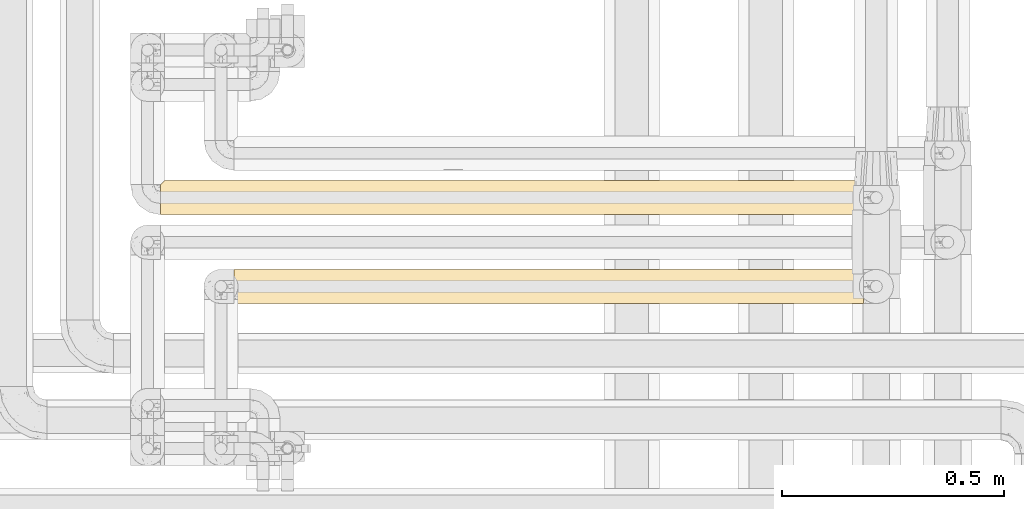
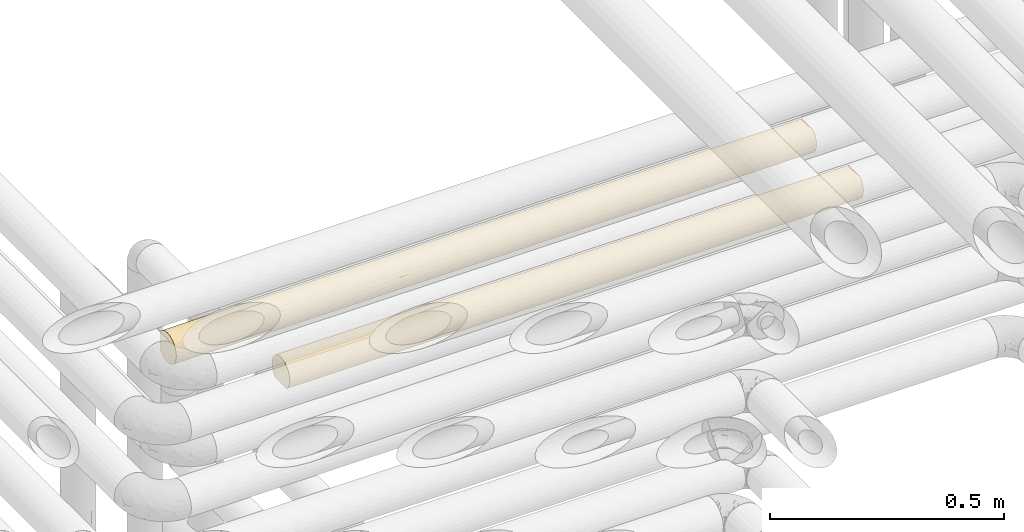
# One storey, part 39 of 827: 2 coverings.
"""IFC2X3 building model written with IfcOpenShell, lengths in millimetres."""

from ifc_helpers import new_model, entity, si_unit, converted_unit, derived_unit, direction, frame, origin, place, context, subcontext, project, spatial, faceted_brep, element, save


model = new_model("IFC2X3")

# Units and contexts
model_context = context("Model", 3, precision=0.01, world=origin(), true_north=direction((6.12303176911189e-17, 1.0)))
body_context = subcontext(model_context, "Body", "Model", "MODEL_VIEW")
ifc_project = project(units=[si_unit("LENGTHUNIT", "METRE", prefix="MILLI"), si_unit("AREAUNIT", "SQUARE_METRE"), si_unit("VOLUMEUNIT", "CUBIC_METRE"), converted_unit("PLANEANGLEUNIT", "DEGREE", entity("IfcRatioMeasure", 0.0174532925199433), si_unit("PLANEANGLEUNIT", "RADIAN"), dimensions=[0, 0, 0, 0, 0, 0, 0]), si_unit("MASSUNIT", "GRAM", prefix="KILO"), derived_unit("MASSDENSITYUNIT", [(si_unit("MASSUNIT", "GRAM", prefix="KILO"), 1), (si_unit("LENGTHUNIT", "METRE"), -3)]), derived_unit("MOMENTOFINERTIAUNIT", [(si_unit("LENGTHUNIT", "METRE"), 4)]), si_unit("TIMEUNIT", "SECOND"), si_unit("FREQUENCYUNIT", "HERTZ"), si_unit("THERMODYNAMICTEMPERATUREUNIT", "DEGREE_CELSIUS"), derived_unit("THERMALTRANSMITTANCEUNIT", [(si_unit("MASSUNIT", "GRAM", prefix="KILO"), 1), (si_unit("THERMODYNAMICTEMPERATUREUNIT", "KELVIN"), -1), (si_unit("TIMEUNIT", "SECOND"), -3)]), derived_unit("VOLUMETRICFLOWRATEUNIT", [(si_unit("LENGTHUNIT", "METRE"), 3), (si_unit("TIMEUNIT", "SECOND"), -1)]), derived_unit("MASSFLOWRATEUNIT", [(si_unit("MASSUNIT", "GRAM", prefix="KILO"), 1), (si_unit("TIMEUNIT", "SECOND"), -1)]), derived_unit("ROTATIONALFREQUENCYUNIT", [(si_unit("TIMEUNIT", "SECOND"), -1)]), si_unit("ELECTRICCURRENTUNIT", "AMPERE"), si_unit("ELECTRICVOLTAGEUNIT", "VOLT"), si_unit("POWERUNIT", "WATT"), si_unit("FORCEUNIT", "NEWTON", prefix="KILO"), si_unit("ILLUMINANCEUNIT", "LUX"), si_unit("LUMINOUSFLUXUNIT", "LUMEN"), si_unit("LUMINOUSINTENSITYUNIT", "CANDELA"), derived_unit("USERDEFINED", [(si_unit("MASSUNIT", "GRAM", prefix="KILO"), -1), (si_unit("LENGTHUNIT", "METRE"), -2), (si_unit("TIMEUNIT", "SECOND"), 3), (si_unit("LUMINOUSFLUXUNIT", "LUMEN"), 1)]), derived_unit("LINEARVELOCITYUNIT", [(si_unit("LENGTHUNIT", "METRE"), 1), (si_unit("TIMEUNIT", "SECOND"), -1)]), si_unit("PRESSUREUNIT", "PASCAL"), derived_unit("USERDEFINED", [(si_unit("LENGTHUNIT", "METRE"), -2), (si_unit("MASSUNIT", "GRAM", prefix="KILO"), 1), (si_unit("TIMEUNIT", "SECOND"), -2)]), derived_unit("LINEARFORCEUNIT", [(si_unit("MASSUNIT", "GRAM", prefix="KILO"), 1), (si_unit("LENGTHUNIT", "METRE"), 1), (si_unit("TIMEUNIT", "SECOND"), -2), (si_unit("LENGTHUNIT", "METRE"), -1)]), derived_unit("PLANARFORCEUNIT", [(si_unit("MASSUNIT", "GRAM", prefix="KILO"), 1), (si_unit("LENGTHUNIT", "METRE"), 1), (si_unit("TIMEUNIT", "SECOND"), -2), (si_unit("LENGTHUNIT", "METRE"), -2)])], contexts=[model_context])

# Site, building, storey
site_placement = place(None, origin())
site = spatial("IfcSite", under=ifc_project, at=site_placement, CompositionType="ELEMENT")
building_placement = place(site_placement, origin())
building = spatial("IfcBuilding", under=site, at=building_placement, CompositionType="ELEMENT")
storey_placement = place(building_placement, frame((0.0, 0.0, 28200.0)))
storey = spatial("IfcBuildingStorey", under=building, at=storey_placement, Name="08", CompositionType="ELEMENT", Elevation=28200.0)

# Coverings
covering_1_placement = place(storey_placement, frame((34855.35, 15450.0, 2960.0)))
element("IfcCovering", 1, at=covering_1_placement, inside=storey, Name=":ADSK_", ObjectType=":ADSK_", PredefinedType="INSULATION", context=body_context, shape_type="Brep", body=[
    faceted_brep([(1584.27, 59.2, 6.74), (1584.27, 67.15, 12.84), (1584.27, 73.25, 20.8), (1584.27, 77.09, 30.06), (1584.27, 78.4, 40.0), (1584.27, 77.51, 48.2), (1584.27, 74.9, 56.01), (1584.27, 70.68, 63.08), (1584.27, 65.05, 69.1), (1584.27, 14.94, 69.1), (1584.27, 9.31, 63.08), (1584.27, 5.09, 56.01), (1584.27, 2.48, 48.2), (1584.27, 1.6, 40.0), (1584.27, 2.9, 30.06), (1584.27, 6.74, 20.8), (1584.27, 12.84, 12.84), (1584.27, 20.8, 6.74), (1584.27, 30.06, 2.9), (1584.27, 40.0, 1.6), (1584.27, 49.93, 2.9), (1.6, 69.1, 14.94), (1.6, 63.08, 9.31), (1.6, 56.01, 5.09), (1.6, 48.2, 2.48), (1.6, 40.0, 1.6), (1.6, 30.06, 2.9), (1.6, 20.8, 6.74), (1.6, 12.84, 12.84), (1.6, 6.74, 20.8), (1.6, 2.9, 30.06), (1.6, 1.6, 40.0), (1.6, 2.9, 49.93), (1.6, 6.74, 59.2), (1.6, 12.84, 67.15), (1.6, 20.8, 73.25), (1.6, 30.06, 77.09), (1.6, 40.0, 78.4), (1.6, 48.2, 77.51), (1.6, 56.01, 74.9), (1.6, 63.08, 70.68), (1.6, 69.1, 65.05), (325.87, 16.62, 9.53), (1101.67, 12.02, 13.69), (1280.29, 16.62, 9.53), (1328.74, 9.53, 16.62), (260.79, 9.53, 16.62), (326.15, 2.41, 32.1), (223.22, 4.85, 24.51), (474.15, 4.52, 25.3), (1364.31, 33.26, 2.19), (1368.52, 25.3, 4.52), (574.48, 2.26, 32.88), (434.34, 1.6, 40.0), (780.34, 4.5, 25.35), (1274.34, 2.38, 32.28), (1367.89, 1.6, 40.0), (1225.68, 1.6, 40.0), (1137.67, 32.77, 2.28), (1225.68, 40.0, 1.6), (563.24, 33.12, 2.22), (819.98, 27.92, 3.54), (531.31, 25.3, 4.52), (246.65, 25.3, 4.52), (326.15, 32.71, 2.29), (567.7, 11.37, 14.4), (1398.66, 4.08, 26.39), (826.08, 2.33, 32.52), (804.78, 18.31, 8.3), (874.6, 9.53, 16.62), (1108.65, 25.3, 4.52), (1046.38, 2.24, 33.01), (564.73, 17.59, 8.81), (217.97, 40.0, 1.6), (217.97, 1.6, 40.0), (1045.77, 18.18, 8.39), (1151.52, 1.6, 40.0), (935.15, 1.6, 40.0), (867.09, 1.6, 40.0), (1066.7, 7.45, 19.62), (434.34, 40.0, 1.6), (650.71, 40.0, 1.6), (867.09, 40.0, 1.6), (1367.89, 40.0, 1.6), (1151.52, 40.0, 1.6), (650.71, 1.6, 40.0), (982.71, 4.52, 25.29), (1185.09, 4.52, 25.3), (718.77, 1.6, 40.0), (616.82, 49.74, 2.85), (287.23, 52.17, 3.58), (1009.3, 52.1, 3.55), (1259.71, 47.13, 2.26), (218.66, 59.66, 7.01), (712.29, 74.49, 23.13), (923.73, 76.93, 29.51), (906.39, 73.76, 21.71), (1375.48, 75.47, 25.3), (1364.99, 77.79, 33.21), (287.24, 66.24, 11.96), (544.14, 66.56, 12.26), (485.18, 59.66, 7.01), (830.9, 47.59, 2.35), (778.98, 54.79, 4.56), (227.27, 78.4, 40.0), (335.45, 77.5, 31.75), (10.29, 77.79, 33.21), (688.07, 76.94, 29.53), (384.99, 74.58, 23.31), (1137.87, 77.72, 32.83), (1230.33, 78.4, 40.0), (1367.59, 63.37, 9.53), (194.06, 71.13, 17.51), (8.5, 76.0, 26.63), (406.86, 70.58, 16.78), (1284.83, 70.46, 16.62), (1121.37, 75.47, 25.3), (1309.49, 54.69, 4.52), (443.64, 78.4, 40.0), (955.85, 68.71, 14.5), (795.9, 61.58, 8.23), (717.19, 70.91, 17.22), (1106.96, 63.37, 9.53), (5.57, 73.07, 20.48), (10.9, 78.4, 40.0), (876.39, 78.4, 40.0), (660.01, 78.4, 40.0), (335.45, 77.5, 48.24), (688.07, 76.94, 50.46), (1324.14, 72.98, 59.66), (1165.25, 68.03, 66.24), (1390.21, 68.15, 66.11), (734.57, 56.36, 74.73), (571.91, 49.12, 77.3), (862.09, 48.51, 77.44), (544.14, 66.56, 67.73), (406.86, 70.58, 63.21), (287.24, 66.24, 68.03), (194.06, 71.13, 62.48), (218.66, 59.66, 72.98), (10.29, 77.79, 46.78), (8.5, 76.0, 53.36), (1073.65, 47.06, 77.74), (1005.88, 56.77, 74.54), (1331.42, 62.51, 71.1), (1358.59, 40.0, 78.4), (1575.57, 46.78, 77.79), (1268.38, 50.2, 77.01), (287.23, 52.17, 76.41), (1150.23, 76.41, 52.17), (1383.53, 76.41, 52.17), (1111.82, 62.49, 71.12), (1220.6, 56.99, 74.43), (1580.3, 59.51, 73.07), (384.99, 74.58, 56.68), (988.17, 77.78, 46.82), (910.18, 75.77, 53.94), (1070.86, 72.93, 59.74), (5.57, 73.07, 59.51), (1577.37, 53.36, 76.0), (1574.97, 40.0, 78.4), (857.32, 64.49, 69.57), (485.18, 59.66, 72.98), (217.97, 40.0, 78.4), (355.53, 40.0, 78.4), (434.34, 40.0, 78.4), (709.48, 40.0, 78.4), (717.19, 70.91, 62.77), (730.61, 74.51, 56.82), (925.85, 40.0, 78.4), (1142.22, 40.0, 78.4), (301.04, 16.62, 70.46), (326.15, 2.26, 47.13), (447.99, 32.83, 77.72), (220.87, 33.21, 77.79), (210.38, 25.3, 75.47), (576.56, 3.55, 52.1), (1391.8, 17.51, 71.13), (1200.87, 23.31, 74.58), (1179.0, 16.78, 70.58), (464.49, 25.3, 75.47), (1577.37, 26.63, 76.0), (218.27, 9.53, 63.37), (1250.41, 31.75, 77.5), (1575.57, 33.21, 77.79), (1298.62, 11.96, 66.24), (1298.63, 3.58, 52.17), (897.8, 29.53, 76.94), (630.01, 14.5, 68.71), (789.96, 8.23, 61.58), (868.67, 17.22, 70.91), (806.88, 4.56, 54.79), (754.96, 2.35, 47.59), (969.05, 2.85, 49.74), (276.37, 4.52, 54.69), (1367.2, 7.01, 59.66), (1041.72, 12.26, 66.56), (1100.68, 7.01, 59.66), (478.91, 9.53, 63.37), (873.57, 23.13, 74.49), (662.13, 29.51, 76.93), (679.47, 21.71, 73.76), (1580.3, 20.48, 73.07)], [[[0, 1, 2, 3, 4, 5, 6, 7, 8, 9, 10, 11, 12, 13, 14, 15, 16, 17, 18, 19, 20]], [[21, 22, 23, 24, 25, 26, 27, 28, 29, 30, 31, 32, 33, 34, 35, 36, 37, 38, 39, 40, 41]], [[28, 27, 42]], [[43, 44, 45]], [[46, 28, 42]], [[47, 48, 49]], [[50, 18, 51]], [[52, 53, 47]], [[49, 54, 52]], [[55, 13, 56, 57]], [[58, 59, 50]], [[60, 61, 62]], [[27, 26, 63]], [[17, 16, 44]], [[63, 64, 62]], [[63, 42, 27]], [[46, 65, 49]], [[18, 17, 51]], [[44, 16, 45]], [[14, 55, 66]], [[52, 54, 67]], [[68, 69, 65]], [[44, 70, 51]], [[42, 63, 62]], [[57, 71, 55]], [[65, 42, 72]], [[26, 25, 73]], [[62, 64, 60]], [[74, 30, 47]], [[28, 46, 29]], [[16, 15, 45]], [[18, 50, 19]], [[43, 68, 75]], [[65, 46, 42]], [[47, 49, 52]], [[71, 57, 76, 77, 78]], [[48, 46, 49]], [[65, 72, 68]], [[65, 69, 54]], [[61, 68, 62]], [[43, 75, 44]], [[66, 45, 15]], [[43, 79, 69]], [[73, 64, 26]], [[64, 73, 80]], [[64, 80, 60]], [[26, 64, 63]], [[61, 81, 82]], [[82, 58, 61]], [[60, 81, 61]], [[61, 70, 75]], [[60, 80, 81]], [[44, 51, 17]], [[58, 50, 51]], [[58, 51, 70]], [[50, 59, 83, 19]], [[61, 58, 70]], [[58, 82, 84, 59]], [[47, 53, 74]], [[74, 31, 30]], [[48, 30, 29]], [[30, 48, 47]], [[46, 48, 29]], [[65, 54, 49]], [[67, 85, 52]], [[86, 69, 79]], [[71, 67, 86]], [[67, 71, 78]], [[85, 53, 52]], [[55, 71, 87]], [[79, 45, 87]], [[68, 43, 69]], [[61, 75, 68]], [[70, 44, 75]], [[45, 79, 43]], [[86, 79, 87]], [[71, 86, 87]], [[69, 86, 54]], [[66, 55, 87]], [[13, 55, 14]], [[45, 66, 87]], [[15, 14, 66]], [[67, 78, 88, 85]], [[86, 67, 54]], [[42, 62, 72]], [[62, 68, 72]], [[89, 80, 90]], [[91, 92, 84]], [[93, 23, 22]], [[94, 95, 96]], [[3, 97, 98]], [[97, 3, 2]], [[90, 73, 24]], [[22, 99, 93]], [[99, 100, 101]], [[91, 102, 103]], [[84, 82, 81, 102]], [[93, 101, 90]], [[92, 83, 59, 84]], [[104, 105, 106]], [[105, 107, 108]], [[109, 110, 98]], [[21, 99, 22]], [[1, 0, 111]], [[112, 113, 108]], [[23, 90, 24]], [[114, 112, 108]], [[103, 102, 89]], [[115, 116, 97]], [[115, 2, 1]], [[113, 106, 105]], [[20, 117, 0]], [[104, 118, 105]], [[119, 120, 121]], [[122, 119, 115]], [[111, 117, 122]], [[112, 21, 123]], [[114, 121, 100]], [[89, 90, 101]], [[24, 73, 25]], [[106, 124, 104]], [[125, 95, 107]], [[105, 108, 113]], [[125, 109, 95]], [[108, 107, 94]], [[111, 115, 1]], [[96, 119, 121]], [[101, 120, 103]], [[3, 98, 4]], [[102, 81, 89]], [[83, 92, 20]], [[122, 117, 91]], [[117, 111, 0]], [[80, 73, 90]], [[115, 111, 122]], [[20, 19, 83]], [[91, 117, 92]], [[20, 92, 117]], [[115, 97, 2]], [[109, 98, 97]], [[109, 97, 116]], [[4, 98, 110]], [[95, 109, 116]], [[125, 110, 109]], [[96, 95, 116]], [[107, 118, 126, 125]], [[115, 96, 116]], [[94, 96, 121]], [[115, 119, 96]], [[120, 119, 122]], [[91, 120, 122]], [[120, 101, 100]], [[114, 100, 99]], [[120, 100, 121]], [[99, 21, 112]], [[114, 108, 94]], [[112, 123, 113]], [[99, 112, 114]], [[94, 121, 114]], [[95, 94, 107]], [[101, 93, 99]], [[23, 93, 90]], [[118, 107, 105]], [[84, 102, 91]], [[101, 103, 89]], [[91, 103, 120]], [[81, 80, 89]], [[118, 127, 128]], [[129, 130, 131]], [[132, 133, 134]], [[135, 136, 137]], [[136, 138, 137]], [[40, 139, 137]], [[140, 141, 127]], [[142, 143, 134]], [[144, 131, 130]], [[5, 4, 110]], [[145, 146, 147]], [[38, 148, 39]], [[110, 149, 150]], [[130, 151, 144]], [[5, 150, 6]], [[152, 153, 144]], [[127, 141, 154]], [[7, 6, 129]], [[110, 150, 5]], [[155, 128, 156]], [[157, 130, 129]], [[139, 39, 148]], [[7, 131, 8]], [[158, 138, 141]], [[137, 41, 40]], [[152, 159, 153]], [[145, 160, 146]], [[134, 143, 132]], [[159, 147, 146]], [[125, 128, 155]], [[104, 124, 140]], [[153, 8, 144]], [[130, 157, 161]], [[162, 132, 161]], [[137, 139, 162]], [[148, 163, 164, 165]], [[118, 104, 127]], [[151, 143, 152]], [[135, 137, 162]], [[138, 158, 41]], [[148, 38, 163]], [[133, 165, 166]], [[150, 129, 6]], [[155, 110, 125]], [[157, 129, 149]], [[140, 127, 104]], [[127, 154, 128]], [[167, 168, 154]], [[157, 156, 168]], [[133, 166, 134]], [[162, 148, 133]], [[38, 37, 163]], [[165, 133, 148]], [[129, 150, 149]], [[134, 166, 169]], [[147, 142, 170]], [[161, 132, 143]], [[133, 132, 162]], [[161, 143, 151]], [[161, 167, 135]], [[156, 157, 149]], [[161, 157, 167]], [[155, 156, 149]], [[168, 156, 128]], [[110, 155, 149]], [[118, 128, 125, 126]], [[8, 131, 144]], [[129, 131, 7]], [[161, 135, 162]], [[136, 167, 154]], [[167, 136, 135]], [[154, 141, 138]], [[137, 138, 41]], [[154, 138, 136]], [[154, 168, 128]], [[157, 168, 167]], [[161, 151, 130]], [[152, 143, 147]], [[159, 152, 147]], [[144, 151, 152]], [[39, 139, 40]], [[162, 139, 148]], [[147, 170, 145]], [[143, 142, 147]], [[142, 169, 170]], [[169, 142, 134]], [[34, 171, 35]], [[53, 172, 74]], [[173, 164, 174]], [[36, 175, 174]], [[176, 172, 53]], [[177, 178, 179]], [[171, 180, 175]], [[181, 178, 177]], [[34, 33, 182]], [[145, 183, 184]], [[175, 36, 35]], [[9, 185, 10]], [[183, 145, 170]], [[186, 56, 12]], [[183, 187, 178]], [[188, 189, 190]], [[191, 192, 193]], [[32, 194, 33]], [[185, 195, 10]], [[185, 196, 197]], [[195, 11, 10]], [[11, 186, 12]], [[191, 176, 192]], [[193, 76, 186]], [[198, 188, 171]], [[181, 184, 183]], [[197, 186, 195]], [[199, 200, 201]], [[192, 53, 85, 88, 78, 77]], [[182, 194, 198]], [[177, 9, 202]], [[179, 190, 196]], [[193, 186, 197]], [[12, 56, 13]], [[184, 160, 145]], [[166, 200, 187]], [[183, 178, 181]], [[166, 173, 200]], [[178, 187, 199]], [[182, 171, 34]], [[201, 188, 190]], [[197, 189, 191]], [[36, 174, 37]], [[192, 77, 193]], [[74, 172, 32]], [[198, 194, 176]], [[194, 182, 33]], [[186, 76, 57, 56]], [[171, 182, 198]], [[32, 31, 74]], [[176, 194, 172]], [[32, 172, 194]], [[171, 175, 35]], [[173, 174, 175]], [[173, 175, 180]], [[174, 164, 163, 37]], [[200, 173, 180]], [[173, 166, 165, 164]], [[201, 200, 180]], [[187, 170, 169, 166]], [[171, 201, 180]], [[199, 201, 190]], [[171, 188, 201]], [[189, 188, 198]], [[176, 189, 198]], [[189, 197, 196]], [[179, 196, 185]], [[189, 196, 190]], [[185, 9, 177]], [[179, 178, 199]], [[177, 202, 181]], [[185, 177, 179]], [[199, 190, 179]], [[200, 199, 187]], [[197, 195, 185]], [[11, 195, 186]], [[170, 187, 183]], [[53, 192, 176]], [[197, 191, 193]], [[176, 191, 189]], [[77, 76, 193]], [[184, 181, 202, 9, 8, 153, 159, 146, 160]], [[41, 158, 141, 140, 124, 106, 113, 123, 21]]]),
])
covering_2_placement = place(storey_placement, frame((35020.39, 15250.0, 2960.0)))
element("IfcCovering", 2, at=covering_2_placement, inside=storey, Name=":ADSK_", ObjectType=":ADSK_", PredefinedType="INSULATION", context=body_context, shape_type="Brep", body=[
    faceted_brep([(1.6, 2.48, 31.79), (1.6, 1.6, 40.0), (1.6, 2.9, 49.93), (1.6, 6.74, 59.2), (1.6, 12.84, 67.15), (1.6, 20.8, 73.25), (1.6, 30.06, 77.09), (1.6, 40.0, 78.4), (1.6, 49.93, 77.09), (1.6, 59.2, 73.25), (1.6, 67.15, 67.15), (1.6, 73.25, 59.2), (1.6, 77.09, 49.93), (1.6, 78.4, 40.0), (1.6, 77.51, 31.79), (1.6, 74.9, 23.98), (1.6, 70.68, 16.91), (1.6, 65.05, 10.9), (1.6, 14.94, 10.9), (1.6, 9.31, 16.91), (1.6, 5.09, 23.98), (1419.23, 2.9, 30.06), (1419.23, 6.74, 20.8), (1419.23, 12.84, 12.84), (1419.23, 20.8, 6.74), (1419.23, 30.06, 2.9), (1419.23, 40.0, 1.6), (1419.23, 49.93, 2.9), (1419.23, 59.2, 6.74), (1419.23, 67.15, 12.84), (1419.23, 73.25, 20.8), (1419.23, 77.09, 30.06), (1419.23, 78.4, 40.0), (1419.23, 77.51, 48.2), (1419.23, 74.9, 56.01), (1419.23, 70.68, 63.08), (1419.23, 65.05, 69.1), (1419.23, 14.94, 69.1), (1419.23, 9.31, 63.08), (1419.23, 5.09, 56.01), (1419.23, 2.48, 48.2), (1419.23, 1.6, 40.0), (1229.7, 75.47, 25.3), (1110.43, 77.61, 32.28), (335.45, 48.23, 2.49), (688.9, 50.52, 3.07), (443.64, 40.0, 1.6), (1131.67, 70.46, 16.62), (991.15, 75.47, 25.3), (823.92, 57.14, 5.63), (909.55, 48.15, 2.47), (218.54, 72.98, 20.33), (483.96, 72.98, 20.33), (286.74, 68.03, 13.75), (406.51, 63.21, 9.4), (542.75, 67.75, 13.46), (286.74, 76.41, 27.82), (798.34, 70.82, 17.1), (694.56, 74.52, 23.19), (1202.85, 40.0, 1.6), (227.27, 40.0, 1.6), (10.9, 40.0, 1.6), (10.29, 46.78, 2.2), (8.5, 53.36, 4.0), (383.15, 56.68, 5.41), (603.56, 57.1, 5.62), (193.87, 62.48, 8.86), (217.97, 78.4, 40.0), (1251.69, 54.69, 4.52), (1166.0, 63.37, 9.53), (5.57, 59.51, 6.92), (616.44, 77.13, 30.24), (876.39, 40.0, 1.6), (660.01, 40.0, 1.6), (939.95, 62.89, 9.17), (1140.96, 47.82, 2.4), (1030.22, 54.69, 4.52), (434.34, 78.4, 40.0), (878.56, 77.56, 32.01), (650.71, 78.4, 40.0), (770.09, 78.4, 40.0), (867.09, 78.4, 40.0), (986.47, 78.4, 40.0), (1202.85, 78.4, 40.0), (713.28, 62.77, 9.08), (553.73, 78.4, 40.0), (1131.67, 9.53, 16.62), (1166.0, 16.62, 9.53), (406.51, 16.78, 9.4), (713.28, 17.22, 9.08), (542.75, 12.24, 13.46), (1251.69, 25.3, 4.52), (1140.96, 32.17, 2.4), (193.87, 17.51, 8.86), (5.57, 20.48, 6.92), (383.15, 23.32, 5.41), (8.5, 26.63, 4.0), (1229.7, 4.52, 25.3), (335.45, 31.76, 2.49), (10.29, 33.21, 2.2), (286.74, 11.96, 13.75), (286.74, 3.58, 27.82), (217.97, 1.6, 40.0), (688.9, 29.47, 3.07), (991.15, 4.52, 25.3), (798.34, 9.17, 17.1), (1110.43, 2.38, 32.28), (940.93, 17.67, 8.75), (1030.22, 25.3, 4.52), (878.56, 2.43, 32.01), (218.54, 7.01, 20.33), (483.96, 7.01, 20.33), (616.44, 2.86, 30.24), (434.34, 1.6, 40.0), (597.6, 22.59, 5.77), (812.14, 23.29, 5.42), (867.09, 1.6, 40.0), (909.55, 31.84, 2.47), (757.89, 5.06, 24.05), (650.71, 1.6, 40.0), (1202.85, 1.6, 40.0), (986.48, 1.6, 40.0), (770.11, 1.6, 40.0), (553.74, 1.6, 40.0), (804.39, 2.86, 49.75), (1134.09, 3.58, 52.17), (1226.95, 17.51, 71.13), (1415.26, 20.48, 73.07), (1202.28, 7.01, 59.66), (823.23, 22.59, 74.22), (731.92, 29.47, 76.92), (608.69, 23.29, 74.57), (217.97, 40.0, 78.4), (254.82, 16.62, 70.46), (1134.08, 11.96, 66.24), (878.08, 12.24, 66.53), (936.86, 7.01, 59.66), (191.13, 4.52, 54.69), (310.4, 2.38, 47.71), (429.67, 4.52, 54.69), (542.26, 2.43, 47.98), (1014.31, 16.78, 70.59), (707.55, 17.22, 70.91), (1193.55, 40.0, 78.4), (1085.37, 31.76, 77.5), (1410.53, 33.21, 77.79), (1037.67, 23.32, 74.58), (169.13, 25.3, 75.47), (279.87, 32.17, 77.59), (289.15, 9.53, 63.37), (1412.33, 26.63, 76.0), (479.9, 17.67, 71.24), (390.6, 25.3, 75.47), (977.18, 40.0, 78.4), (622.48, 9.17, 62.89), (1409.93, 40.0, 78.4), (511.27, 31.84, 77.52), (760.81, 40.0, 78.4), (662.93, 5.06, 55.94), (544.43, 40.0, 78.4), (1085.37, 48.23, 77.5), (731.92, 50.52, 76.92), (1014.31, 63.21, 70.59), (1226.95, 62.48, 71.13), (1134.08, 68.03, 66.24), (1202.28, 72.98, 59.66), (289.15, 70.46, 63.37), (254.82, 63.37, 70.46), (1415.26, 59.51, 73.07), (1412.33, 53.36, 76.0), (1410.53, 46.78, 77.79), (936.86, 72.98, 59.66), (1134.09, 76.41, 52.17), (596.9, 57.14, 74.36), (511.27, 48.15, 77.52), (191.13, 75.47, 54.69), (480.87, 62.89, 70.82), (622.48, 70.82, 62.89), (1037.67, 56.68, 74.58), (169.13, 54.69, 75.47), (279.87, 47.82, 77.59), (390.6, 54.69, 75.47), (878.08, 67.75, 66.53), (726.26, 74.52, 56.8), (429.67, 75.47, 54.69), (310.4, 77.61, 47.71), (817.26, 57.1, 74.37), (804.39, 77.13, 49.75), (542.26, 77.56, 47.98), (707.55, 62.77, 70.91)], [[[0, 1, 2, 3, 4, 5, 6, 7, 8, 9, 10, 11, 12, 13, 14, 15, 16, 17, 18, 19, 20]], [[21, 22, 23, 24, 25, 26, 27, 28, 29, 30, 31, 32, 33, 34, 35, 36, 37, 38, 39, 40, 41]], [[31, 42, 43]], [[44, 45, 46]], [[42, 47, 48]], [[49, 50, 45]], [[51, 52, 53]], [[54, 53, 55]], [[56, 15, 14]], [[30, 42, 31]], [[57, 58, 48]], [[55, 53, 52]], [[27, 26, 59]], [[30, 29, 47]], [[53, 16, 51]], [[60, 61, 62]], [[56, 51, 15]], [[57, 48, 47]], [[44, 63, 64]], [[62, 63, 44]], [[45, 65, 49]], [[54, 66, 53]], [[14, 13, 67]], [[27, 68, 28]], [[47, 29, 69]], [[70, 66, 63]], [[17, 16, 53]], [[52, 56, 71]], [[50, 72, 73]], [[47, 74, 57]], [[46, 60, 44]], [[68, 75, 76]], [[66, 70, 17]], [[56, 67, 77]], [[71, 56, 77]], [[62, 44, 60]], [[44, 64, 45]], [[65, 45, 64]], [[50, 76, 75]], [[29, 28, 69]], [[57, 52, 58]], [[78, 79, 80, 81]], [[78, 81, 43]], [[43, 81, 82, 83]], [[83, 32, 31]], [[74, 47, 69]], [[14, 67, 56]], [[55, 57, 84]], [[68, 69, 28]], [[76, 49, 74]], [[47, 42, 30]], [[43, 42, 48]], [[43, 48, 78]], [[31, 43, 83]], [[58, 78, 48]], [[78, 71, 79]], [[57, 55, 52]], [[84, 65, 54]], [[84, 54, 55]], [[64, 63, 66]], [[53, 66, 17]], [[64, 66, 54]], [[15, 51, 16]], [[52, 51, 56]], [[75, 27, 59]], [[69, 68, 76]], [[27, 75, 68]], [[72, 75, 59]], [[75, 72, 50]], [[73, 46, 45]], [[50, 73, 45]], [[54, 65, 64]], [[49, 65, 84]], [[74, 49, 84]], [[49, 76, 50]], [[57, 74, 84]], [[76, 74, 69]], [[71, 77, 85, 79]], [[52, 71, 58]], [[58, 71, 78]], [[23, 86, 87]], [[88, 89, 90]], [[25, 91, 92]], [[25, 59, 26]], [[93, 18, 94]], [[88, 93, 95]], [[24, 91, 25]], [[96, 95, 93]], [[97, 86, 22]], [[60, 98, 99]], [[24, 23, 87]], [[18, 100, 19]], [[98, 60, 46]], [[101, 102, 0]], [[103, 95, 98]], [[104, 105, 86]], [[106, 104, 97]], [[107, 108, 87]], [[104, 106, 109]], [[100, 110, 19]], [[100, 90, 111]], [[110, 20, 19]], [[20, 101, 0]], [[21, 97, 22]], [[112, 113, 101]], [[22, 86, 23]], [[96, 99, 98]], [[111, 101, 110]], [[114, 103, 115]], [[116, 109, 106]], [[112, 101, 111]], [[0, 102, 1]], [[99, 61, 60]], [[117, 103, 73]], [[98, 95, 96]], [[108, 117, 92]], [[103, 117, 115]], [[104, 118, 105]], [[89, 115, 107]], [[111, 105, 118]], [[109, 119, 112]], [[21, 41, 120]], [[90, 105, 111]], [[59, 92, 72]], [[113, 102, 101]], [[105, 89, 107]], [[86, 105, 107]], [[91, 87, 108]], [[106, 21, 120]], [[86, 97, 104]], [[21, 106, 97]], [[106, 120, 121, 116]], [[109, 118, 104]], [[118, 109, 112]], [[88, 90, 100]], [[105, 90, 89]], [[100, 18, 93]], [[88, 95, 114]], [[93, 94, 96]], [[100, 93, 88]], [[111, 110, 100]], [[20, 110, 101]], [[87, 91, 24]], [[92, 91, 108]], [[115, 117, 108]], [[25, 92, 59]], [[103, 46, 73]], [[72, 92, 117]], [[46, 103, 98]], [[72, 117, 73]], [[114, 115, 89]], [[108, 107, 115]], [[107, 87, 86]], [[88, 114, 89]], [[103, 114, 95]], [[109, 116, 122, 119]], [[112, 119, 123, 113]], [[111, 118, 112]], [[124, 121, 125]], [[126, 37, 127]], [[128, 39, 38]], [[129, 130, 131]], [[6, 132, 7]], [[5, 4, 133]], [[125, 120, 40]], [[38, 134, 128]], [[134, 135, 136]], [[137, 3, 2]], [[138, 139, 137]], [[123, 140, 138]], [[128, 136, 125]], [[141, 142, 135]], [[143, 144, 145]], [[130, 146, 144]], [[6, 147, 148]], [[37, 134, 38]], [[137, 149, 3]], [[126, 150, 146]], [[39, 125, 40]], [[146, 141, 126]], [[151, 152, 133]], [[5, 147, 6]], [[149, 133, 4]], [[150, 145, 144]], [[139, 138, 140]], [[143, 153, 144]], [[139, 154, 149]], [[3, 149, 4]], [[124, 125, 136]], [[40, 120, 41]], [[145, 155, 143]], [[156, 130, 157]], [[144, 146, 150]], [[152, 156, 148]], [[130, 156, 131]], [[139, 158, 154]], [[142, 131, 151]], [[136, 154, 158]], [[140, 122, 124]], [[2, 1, 102]], [[135, 154, 136]], [[132, 148, 159]], [[121, 120, 125]], [[154, 142, 151]], [[149, 154, 151]], [[147, 133, 152]], [[138, 2, 102]], [[149, 137, 139]], [[2, 138, 137]], [[138, 102, 113, 123]], [[140, 158, 139]], [[158, 140, 124]], [[141, 135, 134]], [[154, 135, 142]], [[134, 37, 126]], [[141, 146, 129]], [[126, 127, 150]], [[134, 126, 141]], [[136, 128, 134]], [[39, 128, 125]], [[133, 147, 5]], [[148, 147, 152]], [[131, 156, 152]], [[6, 148, 132]], [[130, 153, 157]], [[159, 148, 156]], [[153, 130, 144]], [[159, 156, 157]], [[129, 131, 142]], [[152, 151, 131]], [[151, 133, 149]], [[141, 129, 142]], [[130, 129, 146]], [[140, 123, 119, 122]], [[124, 122, 116, 121]], [[136, 158, 124]], [[153, 160, 161]], [[162, 163, 164]], [[35, 165, 164]], [[166, 10, 167]], [[168, 163, 169]], [[164, 36, 35]], [[170, 169, 160]], [[153, 143, 160]], [[171, 164, 165]], [[172, 165, 34]], [[161, 173, 174]], [[11, 175, 12]], [[176, 177, 166]], [[160, 169, 178]], [[13, 12, 67]], [[179, 180, 181]], [[182, 164, 171]], [[11, 10, 166]], [[177, 183, 184]], [[12, 175, 185]], [[172, 34, 33]], [[8, 179, 9]], [[161, 186, 173]], [[162, 164, 182]], [[82, 172, 83]], [[171, 172, 187]], [[143, 155, 170]], [[184, 175, 166]], [[174, 159, 157]], [[177, 184, 166]], [[163, 168, 36]], [[172, 33, 83]], [[187, 172, 82]], [[170, 160, 143]], [[160, 178, 161]], [[186, 161, 178]], [[174, 181, 180]], [[10, 9, 167]], [[177, 171, 183]], [[188, 80, 79, 85]], [[188, 85, 185]], [[8, 7, 132]], [[185, 85, 77, 67]], [[33, 32, 83]], [[176, 166, 167]], [[182, 177, 189]], [[179, 167, 9]], [[181, 173, 176]], [[166, 175, 11]], [[185, 175, 184]], [[185, 184, 188]], [[12, 185, 67]], [[183, 188, 184]], [[188, 187, 80]], [[177, 182, 171]], [[189, 186, 162]], [[189, 162, 182]], [[178, 169, 163]], [[164, 163, 36]], [[178, 163, 162]], [[34, 165, 35]], [[171, 165, 172]], [[180, 8, 132]], [[167, 179, 181]], [[8, 180, 179]], [[159, 180, 132]], [[180, 159, 174]], [[157, 153, 161]], [[174, 157, 161]], [[162, 186, 178]], [[173, 186, 189]], [[176, 173, 189]], [[173, 181, 174]], [[177, 176, 189]], [[181, 176, 167]], [[187, 82, 81, 80]], [[171, 187, 183]], [[183, 187, 188]], [[17, 70, 63, 62, 61, 99, 96, 94, 18]], [[145, 150, 127, 37, 36, 168, 169, 170, 155]]]),
])

save(model, "model.ifc")
